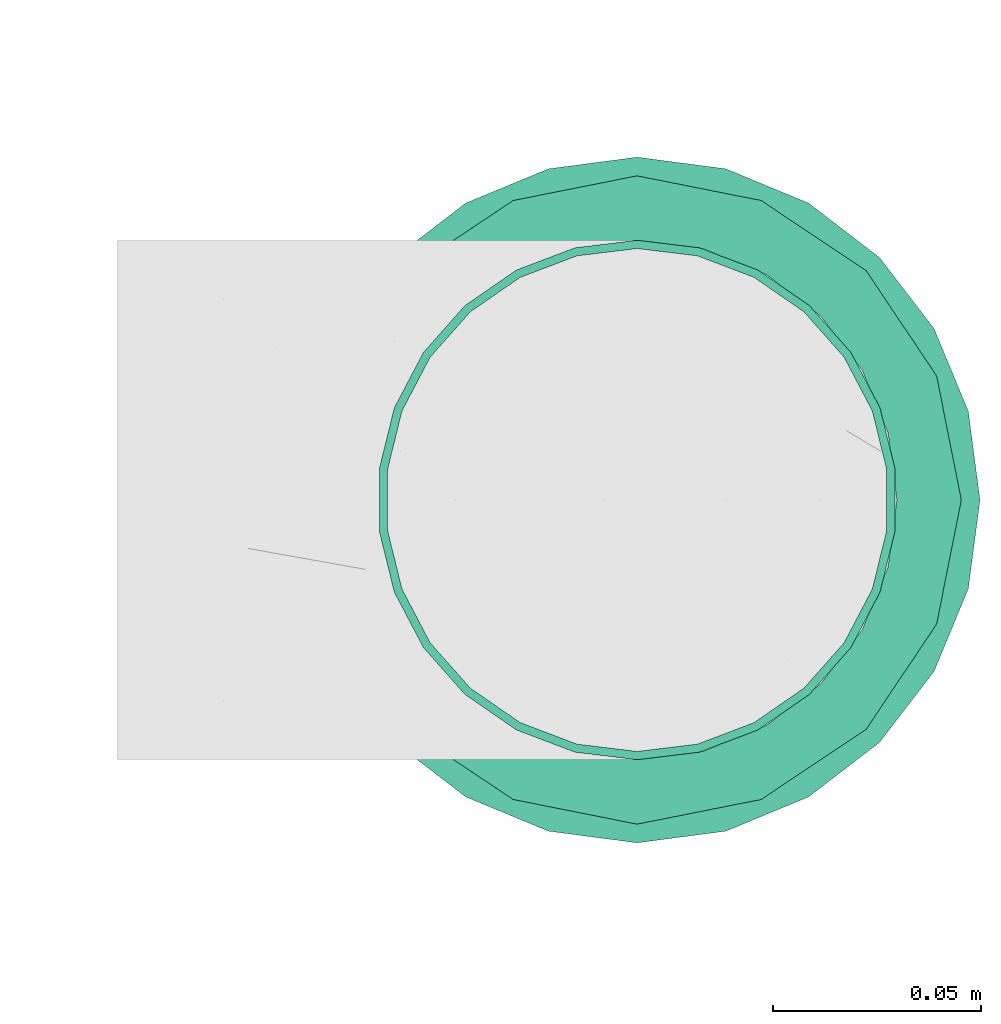
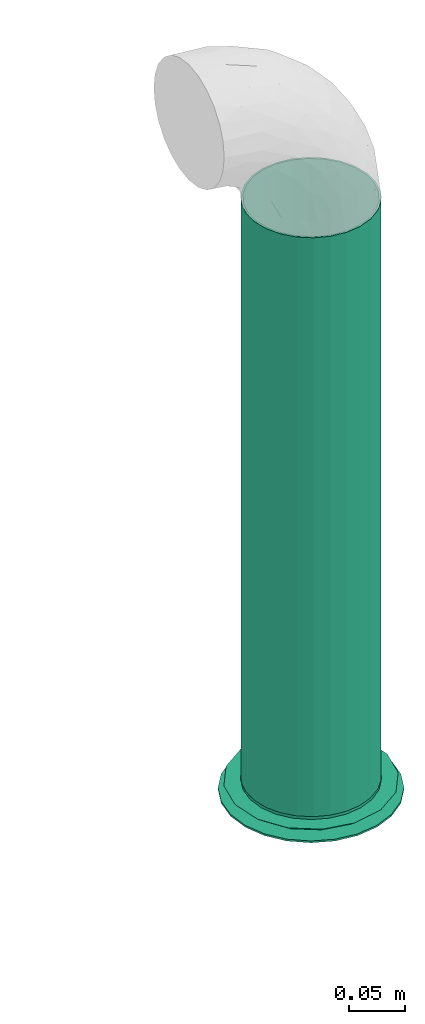
# One storey, part 91 of 103: 1 flow segment, 1 flow terminal.
"""IFC2X3 building model written with IfcOpenShell, lengths in millimetres."""

from ifc_helpers import new_model, entity, si_unit, converted_unit, derived_unit, direction, frame, origin_with_axes, origin_2d_with_axis, place, context, subcontext, project, spatial, hollow_circle, extrude, open_shell, surface_model, source, transform, mapped, material, layer, layer_set, layer_usage, type_object, element, save


model = new_model("IFC2X3")

# Units and contexts
model_context = context("Model", 3, precision=1e-05, world=origin_with_axes(), true_north=direction((0.0, 1.0)))
body_context = subcontext(model_context, "Body", "Model", "MODEL_VIEW")
ifc_project = project(units=[si_unit("AREAUNIT", "SQUARE_METRE"), si_unit("VOLUMEUNIT", "CUBIC_METRE", prefix="DECI"), si_unit("TIMEUNIT", "SECOND"), si_unit("THERMODYNAMICTEMPERATUREUNIT", "DEGREE_CELSIUS"), si_unit("PRESSUREUNIT", "PASCAL"), si_unit("MASSUNIT", "GRAM", prefix="KILO"), si_unit("LENGTHUNIT", "METRE", prefix="MILLI"), si_unit("POWERUNIT", "WATT"), si_unit("ELECTRICCURRENTUNIT", "AMPERE"), si_unit("ELECTRICVOLTAGEUNIT", "VOLT"), derived_unit("VOLUMETRICFLOWRATEUNIT", [(si_unit("VOLUMEUNIT", "CUBIC_METRE", prefix="DECI"), 1), (si_unit("TIMEUNIT", "SECOND"), -1)]), derived_unit("LINEARVELOCITYUNIT", [(si_unit("LENGTHUNIT", "METRE"), 1), (si_unit("TIMEUNIT", "SECOND"), -1)]), derived_unit("MASSDENSITYUNIT", [(si_unit("MASSUNIT", "GRAM", prefix="KILO"), 1), (si_unit("VOLUMEUNIT", "CUBIC_METRE"), -1)]), converted_unit("PLANEANGLEUNIT", "DEGREE", entity("IfcRatioMeasure", 0.01745), si_unit("PLANEANGLEUNIT", "RADIAN"), dimensions=[0, 0, 0, 0, 0, 0, 0])], contexts=[model_context])

# Site, building, storey
site_placement = place(None, origin_with_axes())
site = spatial("IfcSite", under=ifc_project, at=site_placement, CompositionType="ELEMENT")
building_placement = place(site_placement, origin_with_axes())
building = spatial("IfcBuilding", under=site, at=building_placement, Name="mc-building", CompositionType="ELEMENT")
storey_placement = place(building_placement, frame((0.0, 0.0, 5900.0), z_axis=(0.0, 0.0, 1.0), x_axis=(1.0, 0.0, 0.0)))
storey = spatial("IfcBuildingStorey", under=building, at=storey_placement, Name="3. Korrus", CompositionType="ELEMENT", Elevation=5900.0)

# Flow terminal
air_terminal_type = type_object("IfcAirTerminalType", Name="125", PredefinedType="NOTDEFINED")
shared_shape_1 = source(origin_with_axes(), body_context, "Body", "SurfaceModel", [
    surface_model("IfcShellBasedSurfaceModel", [(11.2, 41.25, -71.4471), (11.2, 0.0, -82.5), (11.2, 21.35257, -79.68888), (11.2, 71.4471, -41.25), (11.2, 58.33631, -58.33631), (11.2, 79.68888, -21.35257), (11.2, 82.5, 0.0), (11.2, -79.68888, -21.35257), (11.2, -41.25, -71.4471), (11.2, -21.35257, -79.68888), (11.2, -58.33631, -58.33631), (11.2, -71.4471, -41.25), (11.2, 79.68888, 21.35257), (11.2, 71.4471, 41.25), (11.2, 58.33631, 58.33631), (11.2, 41.25, 71.4471), (11.2, 21.35257, 79.68888), (11.2, -58.33631, 58.33631), (11.2, -21.35257, 79.68888), (11.2, 0.0, 82.5), (11.2, -79.68888, 21.35257), (11.2, -71.4471, 41.25), (11.2, -82.5, 0.0), (11.2, -41.25, 71.4471), (9.2, 21.35257, 79.68888), (9.2, -21.35257, 79.68888), (9.2, 0.0, 82.5), (9.2, 58.33631, 58.33631), (9.2, 41.25, 71.4471), (9.2, 71.4471, 41.25), (9.2, 79.68888, 21.35257), (9.2, -58.33631, 58.33631), (9.2, -41.25, 71.4471), (9.2, -79.68888, 21.35257), (9.2, -71.4471, 41.25), (9.2, -58.33631, -58.33631), (9.2, -82.5, 0.0), (9.2, 79.68888, -21.35257), (9.2, 41.25, -71.4471), (9.2, 71.4471, -41.25), (9.2, -41.25, -71.4471), (9.2, 58.33631, -58.33631), (9.2, 0.0, -82.5), (9.2, 21.35257, -79.68888), (9.2, -71.4471, -41.25), (9.2, -79.68888, -21.35257), (9.2, -21.35257, -79.68888), (9.2, 82.5, 0.0), (9.2, 19.5, 33.77499), (9.2, 0.0, 39.0), (9.2, -19.5, 33.77499), (9.2, -39.0, 0.0), (9.2, 33.77499, 19.5), (9.2, 39.0, 0.0), (9.2, -33.77499, 19.5), (9.2, 0.0, -39.0), (9.2, -33.77499, -19.5), (9.2, -19.5, -33.77499), (9.2, 33.77499, -19.5), (9.2, 19.5, -33.77499), (6.2, 25.24133, 18.3389), (6.2, 31.2, 0.0), (6.2, 9.64133, 29.67296), (6.2, -25.24133, 18.3389), (6.2, -9.64133, 29.67296), (6.2, -31.2, 0.0), (6.2, 25.24133, -18.3389), (6.2, 9.64133, -29.67296), (6.2, -9.64133, -29.67296), (6.2, -25.24133, -18.3389), (9.2, 37.1621, -6.85914), (6.2, 28.22067, -9.16945), (9.2, 35.3242, -13.71829), (6.2, -17.44133, -24.00593), (9.2, -26.6375, -26.6375), (6.2, -28.22067, -9.16945), (9.2, -37.1621, -6.85914), (6.2, 17.44133, -24.00593), (9.2, 9.75, -36.3875), (6.2, 0.0, -29.67296), (9.2, -35.3242, -13.71829), (9.2, 26.6375, -26.6375), (9.2, -9.75, -36.3875), (9.2, -37.1621, 6.85914), (6.2, -28.22067, 9.16945), (9.2, -35.3242, 13.71829), (6.2, 17.44133, 24.00593), (9.2, 26.6375, 26.6375), (6.2, 28.22067, 9.16945), (9.2, 37.1621, 6.85914), (6.2, -17.44133, 24.00593), (9.2, -9.75, 36.3875), (6.2, 0.0, 29.67296), (9.2, 35.3242, 13.71829), (9.2, -26.6375, 26.6375), (9.2, 9.75, 36.3875), (6.2, -26.86438, 64.85634), (6.2, -49.63889, 49.63889), (6.2, -64.85634, 26.86438), (6.2, -70.2, 0.0), (6.2, 64.85634, 26.86438), (6.2, 0.0, 70.2), (6.2, 26.86438, 64.85634), (6.2, 49.63889, 49.63889), (6.2, 70.2, 0.0), (6.2, -64.85634, -26.86438), (6.2, -49.63889, -49.63889), (6.2, -26.86438, -64.85634), (6.2, 26.86438, -64.85634), (6.2, 0.0, -70.2), (6.2, 64.85634, -26.86438), (6.2, 49.63889, -49.63889), (0.0, -29.84931, 72.0626), (0.0, 0.0, 78.0), (0.0, 29.84931, 72.0626), (0.0, 55.15433, 55.15433), (0.0, 78.0, 0.0), (0.0, -55.15433, 55.15433), (0.0, -72.0626, 29.84931), (0.0, -78.0, 0.0), (0.0, 72.0626, 29.84931), (0.0, -72.0626, -29.84931), (0.0, 72.0626, -29.84931), (0.0, 55.15433, -55.15433), (0.0, 29.84931, -72.0626), (0.0, -55.15433, -55.15433), (0.0, -29.84931, -72.0626), (0.0, 0.0, -78.0), (6.2, 66.75025, -17.34304), (0.0, 63.60847, -42.50182), (6.2, 57.24762, -38.25164), (0.0, -14.92465, -75.0313), (6.2, -13.43219, -67.52817), (0.0, 42.50182, -63.60847), (6.2, 38.25164, -57.24762), (0.0, 75.0313, -14.92465), (0.0, 14.92465, -75.0313), (6.2, 13.43219, -67.52817), (0.0, -74.16695, -19.27005), (6.2, -67.52817, -13.43219), (0.0, -42.50182, -63.60847), (6.2, -38.25164, -57.24762), (0.0, -63.60847, -42.50182), (6.2, -57.24762, -38.25164), (6.2, -66.75025, 17.34304), (0.0, -63.60847, 42.50182), (6.2, -57.24762, 38.25164), (0.0, 14.92465, 75.0313), (6.2, 13.43219, 67.52817), (0.0, -42.50182, 63.60847), (6.2, -38.25164, 57.24762), (0.0, -75.0313, 14.92465), (0.0, -14.92465, 75.0313), (6.2, -13.43219, 67.52817), (0.0, 74.16695, 19.27005), (6.2, 67.52817, 13.43219), (0.0, 42.50182, 63.60847), (6.2, 38.25164, 57.24762), (0.0, 63.60847, 42.50182), (6.2, 57.24762, 38.25164), (-3.1, 16.17619, 60.37037), (-3.1, -31.25, 54.12659), (-3.1, 0.0, 62.5), (-3.1, 54.12659, 31.25), (-3.1, 31.25, 54.12659), (-3.1, 44.19417, 44.19417), (-3.1, -54.12659, -31.25), (-3.1, -54.12659, 31.25), (-3.1, -44.19417, 44.19417), (-3.1, -16.17619, 60.37037), (-3.1, -62.5, 0.0), (-3.1, -60.37037, 16.17619), (-3.1, 60.37037, 16.17619), (-3.1, 62.5, 0.0), (-3.1, 60.37037, -16.17619), (-3.1, 54.12659, -31.25), (-3.1, 44.19417, -44.19417), (-3.1, 31.25, -54.12659), (-3.1, 16.17619, -60.37037), (-3.1, -31.25, -54.12659), (-3.1, -44.19417, -44.19417), (-3.1, -60.37037, -16.17619), (-3.1, 0.0, -62.5), (-3.1, -16.17619, -60.37037), (0.0, 31.25, -54.12659), (0.0, -54.12659, -31.25), (0.0, 16.17619, -60.37037), (0.0, 54.12659, -31.25), (0.0, 44.19417, -44.19417), (0.0, 60.37037, -16.17619), (0.0, 62.5, 0.0), (0.0, 54.12659, 31.25), (0.0, 16.17619, 60.37037), (0.0, 0.0, -62.5), (0.0, -31.25, -54.12659), (0.0, -16.17619, -60.37037), (0.0, -44.19417, -44.19417), (0.0, -62.5, 0.0), (0.0, -60.37037, -16.17619), (0.0, 44.19417, 44.19417), (0.0, -54.12659, 31.25), (0.0, 31.25, 54.12659), (0.0, 0.0, 62.5), (0.0, -60.37037, 16.17619), (0.0, -31.25, 54.12659), (0.0, -44.19417, 44.19417), (0.0, -16.17619, 60.37037), (0.0, 60.37037, 16.17619), (-43.1, -14.75269, 55.05777), (-43.1, 0.0, 57.0), (-43.1, 14.75269, 55.05777), (-43.1, 28.5, 49.36345), (-43.1, 40.30508, 40.30508), (-43.1, 49.36345, 28.5), (-43.1, 55.05777, 14.75269), (-43.1, -28.5, 49.36345), (-43.1, -49.36345, 28.5), (-43.1, -40.30508, 40.30508), (-43.1, -57.0, 0.0), (-43.1, -55.05777, 14.75269), (-43.1, -40.30508, -40.30508), (-43.1, 57.0, 0.0), (-43.1, 55.05777, -14.75269), (-43.1, 28.5, -49.36345), (-43.1, 49.36345, -28.5), (-43.1, 14.75269, -55.05777), (-43.1, 40.30508, -40.30508), (-43.1, -49.36345, -28.5), (-43.1, -55.05777, -14.75269), (-43.1, -28.5, -49.36345), (-43.1, 0.0, -57.0), (-43.1, -14.75269, -55.05777), (-3.1, 57.0, 0.0), (-3.1, 14.75269, -55.05777), (-3.1, 28.5, -49.36345), (-3.1, 55.05777, -14.75269), (-3.1, 40.30508, -40.30508), (-3.1, 49.36345, -28.5), (-3.1, 55.05777, 14.75269), (-3.1, -28.5, -49.36345), (-3.1, 0.0, -57.0), (-3.1, -14.75269, -55.05777), (-3.1, -49.36345, -28.5), (-3.1, -57.0, 0.0), (-3.1, -55.05777, -14.75269), (-3.1, -40.30508, -40.30508), (-3.1, -49.36345, 28.5), (-3.1, 49.36345, 28.5), (-3.1, 40.30508, 40.30508), (-3.1, 0.0, 57.0), (-3.1, 28.5, 49.36345), (-3.1, 14.75269, 55.05777), (-3.1, -14.75269, 55.05777), (-3.1, -55.05777, 14.75269), (-3.1, -28.5, 49.36345), (-3.1, -40.30508, 40.30508)], [open_shell([[[0, 1, 2]], [[3, 0, 4]], [[5, 6, 0]], [[5, 0, 3]], [[7, 0, 6]], [[1, 8, 9]], [[1, 0, 8]], [[10, 7, 11]], [[10, 8, 0]], [[7, 10, 0]], [[6, 12, 7]], [[12, 13, 14]], [[12, 14, 15]], [[12, 16, 17]], [[16, 12, 15]], [[18, 16, 19]], [[20, 17, 21]], [[22, 7, 20]], [[17, 18, 23]], [[20, 12, 17]], [[16, 18, 17]], [[20, 7, 12]], [[24, 25, 26]], [[27, 24, 28]], [[27, 29, 30]], [[27, 30, 24]], [[31, 24, 30]], [[25, 31, 32]], [[25, 24, 31]], [[31, 33, 34]], [[31, 30, 33]], [[35, 36, 33]], [[33, 30, 37]], [[33, 37, 35]], [[38, 37, 39]], [[40, 37, 38]], [[38, 39, 41]], [[42, 38, 43]], [[36, 44, 45]], [[35, 44, 36]], [[40, 42, 46]], [[35, 37, 40]], [[38, 42, 40]], [[37, 30, 47]], [[45, 7, 36]], [[44, 11, 45]], [[8, 35, 40]], [[44, 35, 10]], [[9, 40, 46]], [[45, 11, 7]], [[7, 22, 36]], [[9, 8, 40]], [[10, 35, 8]], [[10, 11, 44]], [[1, 9, 46]], [[46, 42, 1]], [[43, 2, 42]], [[38, 0, 43]], [[3, 41, 39]], [[38, 41, 4]], [[5, 39, 37]], [[38, 4, 0]], [[0, 2, 43]], [[6, 5, 37]], [[3, 39, 5]], [[3, 4, 41]], [[47, 6, 37]], [[42, 2, 1]], [[30, 12, 47]], [[29, 13, 30]], [[15, 27, 28]], [[29, 27, 14]], [[16, 28, 24]], [[30, 13, 12]], [[12, 6, 47]], [[16, 15, 28]], [[14, 27, 15]], [[14, 13, 29]], [[19, 16, 24]], [[24, 26, 19]], [[25, 18, 26]], [[32, 23, 25]], [[21, 31, 34]], [[32, 31, 17]], [[20, 34, 33]], [[32, 17, 23]], [[23, 18, 25]], [[36, 22, 20]], [[21, 34, 20]], [[21, 17, 31]], [[33, 36, 20]], [[26, 18, 19]], [[48, 49, 50]], [[50, 51, 52]], [[50, 52, 48]], [[53, 52, 51]], [[50, 54, 51]], [[55, 51, 56]], [[55, 56, 57]], [[58, 55, 59]], [[58, 53, 55]], [[55, 53, 51]], [[60, 61, 62]], [[62, 63, 64]], [[65, 63, 62]], [[62, 61, 65]], [[66, 67, 68]], [[65, 68, 69]], [[65, 61, 68]], [[68, 61, 66]], [[61, 70, 71]], [[58, 71, 72]], [[73, 74, 69]], [[56, 75, 69]], [[76, 51, 65]], [[59, 67, 77]], [[73, 68, 57]], [[74, 73, 57]], [[67, 78, 79]], [[70, 61, 53]], [[65, 75, 76]], [[56, 80, 75]], [[66, 81, 77]], [[82, 57, 68]], [[67, 59, 78]], [[59, 77, 81]], [[81, 66, 58]], [[71, 58, 66]], [[82, 79, 55]], [[78, 55, 79]], [[68, 79, 82]], [[75, 80, 76]], [[56, 69, 74]], [[70, 72, 71]], [[65, 83, 84]], [[54, 84, 85]], [[86, 87, 60]], [[52, 88, 60]], [[89, 53, 61]], [[50, 64, 90]], [[86, 62, 48]], [[87, 86, 48]], [[64, 91, 92]], [[83, 65, 51]], [[61, 88, 89]], [[52, 93, 88]], [[63, 94, 90]], [[95, 48, 62]], [[64, 50, 91]], [[50, 90, 94]], [[94, 63, 54]], [[84, 54, 63]], [[95, 92, 49]], [[91, 49, 92]], [[62, 92, 95]], [[88, 93, 89]], [[52, 60, 87]], [[83, 85, 84]], [[96, 97, 98]], [[98, 99, 96]], [[96, 99, 100]], [[101, 96, 102]], [[100, 103, 102]], [[96, 100, 102]], [[99, 104, 100]], [[105, 106, 107]], [[105, 107, 108]], [[108, 107, 109]], [[110, 104, 111]], [[108, 111, 104]], [[99, 108, 104]], [[108, 99, 105]], [[112, 113, 114]], [[112, 114, 115]], [[116, 112, 115]], [[117, 112, 118]], [[119, 118, 112]], [[119, 112, 116]], [[116, 115, 120]], [[121, 116, 122]], [[123, 124, 122]], [[121, 122, 124]], [[125, 121, 126]], [[126, 121, 124]], [[124, 127, 126]], [[116, 121, 119]], [[110, 122, 128]], [[111, 129, 130]], [[107, 131, 132]], [[108, 133, 134]], [[104, 128, 135]], [[116, 104, 135]], [[111, 134, 123]], [[130, 122, 110]], [[136, 124, 137]], [[128, 122, 135]], [[127, 136, 109]], [[111, 123, 129]], [[119, 138, 139]], [[138, 105, 139]], [[140, 141, 106]], [[124, 108, 137]], [[139, 99, 119]], [[108, 124, 133]], [[106, 125, 140]], [[142, 143, 105]], [[123, 134, 133]], [[131, 127, 132]], [[106, 143, 125]], [[141, 126, 107]], [[126, 141, 140]], [[109, 136, 137]], [[138, 121, 105]], [[122, 130, 129]], [[125, 143, 142]], [[107, 126, 131]], [[127, 109, 132]], [[105, 121, 142]], [[98, 118, 144]], [[97, 145, 146]], [[102, 147, 148]], [[96, 149, 150]], [[99, 144, 151]], [[119, 99, 151]], [[97, 150, 117]], [[146, 118, 98]], [[152, 112, 153]], [[144, 118, 151]], [[113, 152, 101]], [[97, 117, 145]], [[116, 154, 155]], [[154, 100, 155]], [[156, 157, 103]], [[112, 96, 153]], [[155, 104, 116]], [[96, 112, 149]], [[103, 115, 156]], [[158, 159, 100]], [[117, 150, 149]], [[147, 113, 148]], [[103, 159, 115]], [[157, 114, 102]], [[114, 157, 156]], [[101, 152, 153]], [[154, 120, 100]], [[118, 146, 145]], [[115, 159, 158]], [[102, 114, 147]], [[113, 101, 148]], [[100, 120, 158]], [[160, 161, 162]], [[163, 160, 164]], [[161, 160, 163]], [[163, 164, 165]], [[163, 166, 167]], [[161, 167, 168]], [[161, 169, 162]], [[167, 170, 171]], [[167, 161, 163]], [[166, 170, 167]], [[163, 172, 173]], [[173, 174, 175]], [[173, 175, 176]], [[177, 178, 173]], [[177, 173, 176]], [[173, 178, 179]], [[166, 179, 180]], [[181, 170, 166]], [[179, 182, 183]], [[166, 163, 179]], [[182, 179, 178]], [[163, 173, 179]], [[184, 185, 186]], [[187, 184, 188]], [[187, 189, 190]], [[184, 187, 191]], [[192, 185, 184]], [[193, 194, 195]], [[193, 186, 194]], [[194, 185, 196]], [[186, 185, 194]], [[185, 197, 198]], [[190, 191, 187]], [[191, 192, 184]], [[192, 191, 199]], [[192, 200, 185]], [[192, 199, 201]], [[202, 200, 192]], [[197, 200, 203]], [[185, 200, 197]], [[200, 204, 205]], [[202, 204, 200]], [[202, 206, 204]], [[191, 190, 207]], [[172, 207, 173]], [[163, 191, 172]], [[201, 165, 164]], [[163, 165, 199]], [[192, 164, 160]], [[172, 191, 207]], [[207, 190, 173]], [[192, 201, 164]], [[199, 165, 201]], [[199, 191, 163]], [[202, 192, 160]], [[160, 162, 202]], [[169, 206, 162]], [[161, 204, 169]], [[200, 168, 167]], [[161, 168, 205]], [[203, 167, 171]], [[161, 205, 204]], [[204, 206, 169]], [[197, 203, 171]], [[200, 167, 203]], [[200, 205, 168]], [[170, 197, 171]], [[162, 206, 202]], [[181, 198, 170]], [[166, 185, 181]], [[194, 180, 179]], [[166, 180, 196]], [[195, 179, 183]], [[181, 185, 198]], [[198, 197, 170]], [[195, 194, 179]], [[196, 180, 194]], [[196, 185, 166]], [[193, 195, 183]], [[183, 182, 193]], [[178, 186, 182]], [[177, 184, 178]], [[187, 176, 175]], [[177, 176, 188]], [[189, 175, 174]], [[177, 188, 184]], [[184, 186, 178]], [[190, 189, 174]], [[187, 175, 189]], [[187, 188, 176]], [[173, 190, 174]], [[182, 186, 193]], [[208, 209, 210]], [[211, 208, 210]], [[212, 213, 214]], [[212, 214, 211]], [[208, 211, 214]], [[215, 216, 217]], [[216, 215, 208]], [[216, 218, 219]], [[216, 208, 214]], [[216, 220, 218]], [[216, 214, 221]], [[220, 216, 222]], [[223, 222, 224]], [[223, 225, 222]], [[223, 224, 226]], [[220, 222, 225]], [[218, 227, 228]], [[220, 227, 218]], [[229, 230, 231]], [[229, 220, 225]], [[230, 229, 225]], [[216, 221, 222]], [[232, 233, 234]], [[235, 234, 236]], [[235, 232, 234]], [[235, 236, 237]], [[238, 239, 233]], [[240, 239, 241]], [[240, 233, 239]], [[242, 243, 244]], [[245, 239, 246]], [[242, 245, 243]], [[238, 233, 232]], [[238, 247, 248]], [[238, 248, 249]], [[250, 251, 249]], [[250, 249, 248]], [[238, 249, 252]], [[243, 246, 253]], [[245, 246, 243]], [[246, 254, 255]], [[254, 246, 252]], [[238, 252, 246]], [[246, 239, 238]], [[214, 238, 221]], [[213, 247, 214]], [[250, 212, 211]], [[213, 212, 248]], [[251, 211, 210]], [[214, 247, 238]], [[238, 232, 221]], [[251, 250, 211]], [[248, 212, 250]], [[248, 247, 213]], [[249, 251, 210]], [[210, 209, 249]], [[254, 215, 217]], [[246, 216, 219]], [[217, 216, 255]], [[253, 219, 218]], [[208, 254, 252]], [[208, 215, 254]], [[252, 249, 208]], [[217, 255, 254]], [[216, 246, 255]], [[253, 246, 219]], [[218, 243, 253]], [[208, 249, 209]], [[228, 244, 218]], [[227, 242, 228]], [[239, 220, 229]], [[227, 220, 245]], [[241, 229, 231]], [[228, 242, 244]], [[244, 243, 218]], [[241, 239, 229]], [[245, 220, 239]], [[245, 242, 227]], [[240, 241, 231]], [[231, 230, 240]], [[233, 230, 225]], [[234, 225, 223]], [[237, 224, 222]], [[221, 235, 222]], [[225, 234, 233]], [[234, 223, 226]], [[234, 226, 236]], [[226, 224, 236]], [[224, 237, 236]], [[235, 237, 222]], [[221, 232, 235]], [[230, 233, 240]]])]),
])
flow_terminal_placement = place(storey_placement, frame((36404.9937, 4322.30408, 2460.0), z_axis=(1.0, 0.0, 0.0), x_axis=(0.0, 0.0, -1.0)))
element("IfcFlowTerminal", 1, at=flow_terminal_placement, inside=storey, type_object=air_terminal_type, Name="125", context=body_context, shape_type="MappedRepresentation", body=[
    mapped(shared_shape_1, transform((0.0, 0.0, 0.0), scale=1.0)),
])

# Flow segment
ifc_material = material(Name="FZ1")
ifc_layer = layer(ifc_material, 0.0)
ifc_layer_set = layer_set([ifc_layer], Name="FZ1")
ifc_layer_usage = layer_usage(ifc_layer_set, "AXIS1", "POSITIVE", 0.0)
duct_segment_type = type_object("IfcDuctSegmentType", Name="Safe", PredefinedType="RIGIDSEGMENT")
shared_shape_2 = source(origin_with_axes(), body_context, "Body", "SweptSolid", [
    extrude(hollow_circle(Radius=62.5, WallThickness=2.0, at=origin_2d_with_axis()), frame((0.0, 0.0, 0.0), z_axis=(1.0, 0.0, 0.0), x_axis=(0.0, 1.0, 0.0)), (0.0, 0.0, 1.0), 626.9),
])
flow_segment_placement = place(storey_placement, frame((36404.9937, 4322.30408, 2463.1), z_axis=(1.0, 0.0, 0.0), x_axis=(0.0, 0.0, 1.0)))
element("IfcFlowSegment", 2, at=flow_segment_placement, inside=storey, type_object=duct_segment_type, material=ifc_layer_usage, Name="Safe", context=body_context, shape_type="MappedRepresentation", body=[
    mapped(shared_shape_2, transform((0.0, 0.0, 0.0), scale=1.0)),
])

save(model, "model.ifc")
